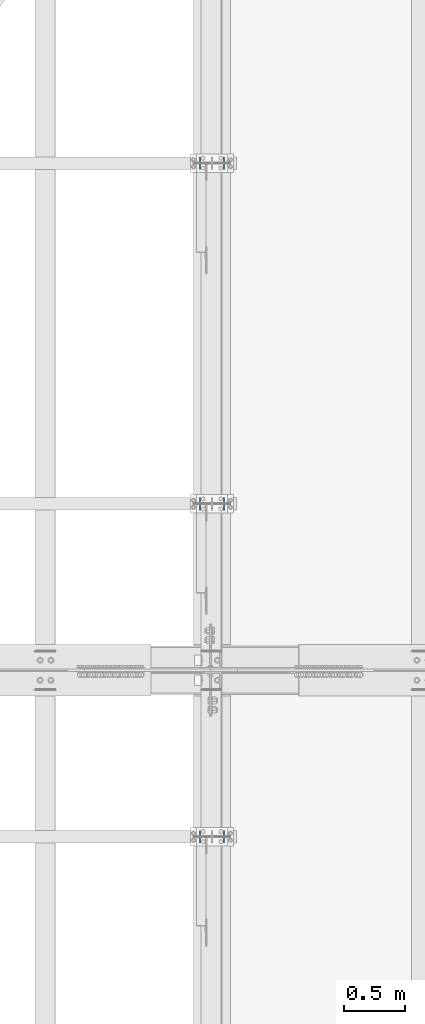
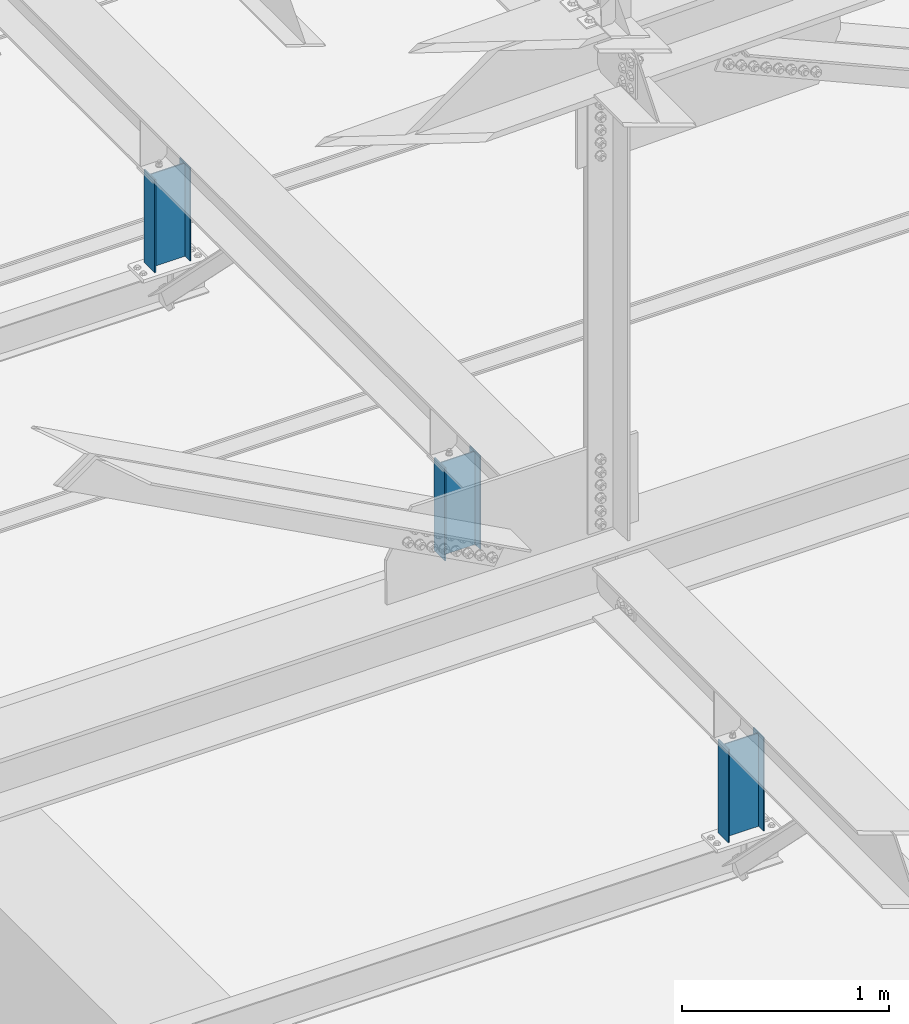
# One storey, part 1516 of 3843: 3 columns, 3 elements without a shape of their own.
"""IFC2X3 building model written with IfcOpenShell, lengths in millimetres."""

from ifc_helpers import new_model, si_unit, frame, origin_with_axes, place, context, subcontext, project, spatial, faceted_brep, material, type_object, element, aggregate, save


model = new_model("IFC2X3")

# Units and contexts
model_context = context("Model", 3, precision=1e-05, world=origin_with_axes())
body_context = subcontext(model_context, "Body", "Model", "MODEL_VIEW")
ifc_project = project(units=[si_unit("LENGTHUNIT", "METRE", prefix="MILLI"), si_unit("AREAUNIT", "SQUARE_METRE"), si_unit("VOLUMEUNIT", "CUBIC_METRE"), si_unit("MASSUNIT", "GRAM", prefix="KILO"), si_unit("TIMEUNIT", "SECOND"), si_unit("PLANEANGLEUNIT", "RADIAN"), si_unit("SOLIDANGLEUNIT", "STERADIAN"), si_unit("THERMODYNAMICTEMPERATUREUNIT", "DEGREE_CELSIUS"), si_unit("LUMINOUSINTENSITYUNIT", "LUMEN")], contexts=[model_context])

# Site, building, storey
site_placement = place(None, origin_with_axes())
site = spatial("IfcSite", under=ifc_project, at=site_placement, CompositionType="ELEMENT")
building_placement = place(site_placement, origin_with_axes())
building = spatial("IfcBuilding", under=site, at=building_placement, Name="Undefined", CompositionType="ELEMENT")
storey_placement = place(building_placement, origin_with_axes())
storey = spatial("IfcBuildingStorey", under=building, at=storey_placement, Name="Undefined", CompositionType="ELEMENT", Elevation=0.0)

# Assembly, column
assembly_1_placement = place(storey_placement, origin_with_axes())
assembly_1 = element("IfcElementAssembly", 1, at=assembly_1_placement, inside=storey, Name="POST", AssemblyPlace="NOTDEFINED", PredefinedType="RIGID_FRAME")
ifc_material = material(Name="STEEL/A992")
column_type = type_object("IfcColumnType", Name="W8X13", PredefinedType="NOTDEFINED")
column_1_placement = place(assembly_1_placement, frame((42062.4, 40830.5, 41503.6), z_axis=(-1.0, 0.0, 0.0), x_axis=(0.0, 0.0, 1.0)))
column_1 = element("IfcColumn", 2, at=column_1_placement, type_object=column_type, material=ifc_material, Name="POST", ObjectType="W8X13", context=body_context, shape_type="Brep", body=[
    faceted_brep([(19.0499994920028, 50.7999999999993, -101.600000000035), (19.0499995237551, 50.7999999999993, -95.2500000000364), (569.912499523743, 50.8000000000029, -95.2500000008076), (569.912499491991, 50.8000000000029, -101.600000000806), (19.0499995237551, 3.17499999999927, -95.2500000000364), (569.912499523743, 3.17500000000291, -95.2500000008076), (19.0500004762507, 3.17499999999927, 95.2499999999636), (569.912500476239, 3.17500000000291, 95.2499999991924), (19.0500004762507, 50.7999999999993, 95.2499999999636), (569.912500476239, 50.8000000000029, 95.2499999991924), (19.050000508003, 50.7999999999993, 101.599999999969), (569.912500507991, 50.8000000000029, 101.599999999191), (19.050000508003, -50.7999999999993, 101.599999999969), (569.912500507991, -50.8000000000029, 101.599999999191), (19.0500004762507, -50.7999999999993, 95.2499999999636), (569.912500476239, -50.8000000000029, 95.2499999991924), (19.0500004762507, -3.17499999999927, 95.2499999999636), (569.912500476239, -3.17500000000291, 95.2499999991924), (19.0499995237551, -3.17499999999927, -95.2500000000364), (569.912499523743, -3.17500000000291, -95.2500000008076), (19.0499995237551, -50.7999999999993, -95.2500000000364), (569.912499523743, -50.8000000000029, -95.2500000008076), (19.0499994920028, -50.7999999999993, -101.600000000035), (569.912499491991, -50.8000000000029, -101.600000000806)], [[[0, 1, 2, 3]], [[1, 4, 5, 2]], [[4, 6, 7, 5]], [[6, 8, 9, 7]], [[8, 10, 11, 9]], [[10, 12, 13, 11]], [[12, 14, 15, 13]], [[14, 16, 17, 15]], [[16, 18, 19, 17]], [[18, 20, 21, 19]], [[20, 22, 23, 21]], [[22, 0, 3, 23]], [[5, 7, 9, 11, 13, 15, 17, 19, 21, 23, 3, 2]], [[22, 20, 18, 16, 14, 12, 10, 8, 6, 4, 1, 0]]]),
])
aggregate(assembly_1, [column_1])

assembly_2_placement = place(storey_placement, origin_with_axes())
assembly_2 = element("IfcElementAssembly", 3, at=assembly_2_placement, inside=storey, Name="POST", AssemblyPlace="NOTDEFINED", PredefinedType="RIGID_FRAME")
column_2_placement = place(assembly_2_placement, frame((42062.4, 43573.7, 41503.6), z_axis=(-1.0, 0.0, 0.0), x_axis=(0.0, 0.0, 1.0)))
column_2 = element("IfcColumn", 4, at=column_2_placement, type_object=column_type, material=ifc_material, Name="POST", ObjectType="W8X13", context=body_context, shape_type="Brep", body=[
    faceted_brep([(19.0499994920028, 50.7999999999993, -101.600000000035), (19.0499995237551, 50.7999999999993, -95.2500000000364), (569.898883661845, 50.8000000000029, -95.2500000008076), (569.898883630092, 50.8000000000029, -101.600000000813), (19.0499995237551, 3.17499999999927, -95.2500000000364), (569.873359039419, 3.17500000000291, -95.2500000008076), (19.0500004762507, 3.17499999999927, 95.2499999999636), (569.873359991914, 3.17500000000291, 95.2499999991924), (19.0500004762507, 50.7999999999993, 95.2499999999636), (569.89888461434, 50.8000000000029, 95.2499999991924), (19.050000508003, 50.7999999999993, 101.599999999969), (569.898884646092, 50.8000000000029, 101.599999999191), (19.050000508003, -50.7999999999993, 101.599999999969), (569.844432118254, -50.8000000000029, 101.599999999191), (19.0500004762507, -50.7999999999993, 95.2499999999636), (569.844432086502, -50.8000000000029, 95.2499999991924), (19.0500004762507, -3.17499999999927, 95.2499999999636), (569.869956708928, -3.17500000000291, 95.2499999991924), (19.0499995237551, -3.17499999999927, -95.2500000000364), (569.869955756432, -3.17500000000291, -95.2500000008076), (19.0499995237551, -50.7999999999993, -95.2500000000364), (569.844431134006, -50.8000000000029, -95.2500000008076), (19.0499994920028, -50.7999999999993, -101.600000000035), (569.844431102254, -50.8000000000029, -101.600000000806)], [[[0, 1, 2, 3]], [[1, 4, 5, 2]], [[4, 6, 7, 5]], [[6, 8, 9, 7]], [[8, 10, 11, 9]], [[10, 12, 13, 11]], [[12, 14, 15, 13]], [[14, 16, 17, 15]], [[16, 18, 19, 17]], [[18, 20, 21, 19]], [[20, 22, 23, 21]], [[22, 0, 3, 23]], [[5, 7, 9, 11, 13, 15, 17, 19, 21, 23, 3, 2]], [[22, 20, 18, 16, 14, 12, 10, 8, 6, 4, 1, 0]]]),
])
aggregate(assembly_2, [column_2])

assembly_3_placement = place(storey_placement, origin_with_axes())
assembly_3 = element("IfcElementAssembly", 5, at=assembly_3_placement, inside=storey, Name="POST", AssemblyPlace="NOTDEFINED", PredefinedType="RIGID_FRAME")
column_3_placement = place(assembly_3_placement, frame((42062.4, 46380.4, 41503.6), z_axis=(-1.0, 0.0, 0.0), x_axis=(0.0, 0.0, 1.0)))
column_3 = element("IfcColumn", 6, at=column_3_placement, type_object=column_type, material=ifc_material, Name="POST", ObjectType="W8X13", context=body_context, shape_type="Brep", body=[
    faceted_brep([(19.0499994920028, 50.7999999999993, -101.600000000035), (19.0499995237551, 50.7999999999993, -95.2500000000364), (569.898883661845, 50.8000000000029, -95.2500000008076), (569.898883630092, 50.8000000000029, -101.600000000813), (19.0499995237551, 3.17499999999927, -95.2500000000364), (569.873359039419, 3.17500000000291, -95.2500000008076), (19.0500004762507, 3.17499999999927, 95.2499999999636), (569.873359991914, 3.17500000000291, 95.2499999991924), (19.0500004762507, 50.7999999999993, 95.2499999999636), (569.89888461434, 50.8000000000029, 95.2499999991924), (19.050000508003, 50.7999999999993, 101.599999999969), (569.898884646092, 50.8000000000029, 101.599999999191), (19.050000508003, -50.7999999999993, 101.599999999969), (569.844432118254, -50.8000000000029, 101.599999999191), (19.0500004762507, -50.7999999999993, 95.2499999999636), (569.844432086502, -50.8000000000029, 95.2499999991924), (19.0500004762507, -3.17499999999927, 95.2499999999636), (569.869956708928, -3.17500000000291, 95.2499999991924), (19.0499995237551, -3.17499999999927, -95.2500000000364), (569.869955756432, -3.17500000000291, -95.2500000008076), (19.0499995237551, -50.7999999999993, -95.2500000000364), (569.844431134006, -50.8000000000029, -95.2500000008076), (19.0499994920028, -50.7999999999993, -101.600000000035), (569.844431102254, -50.8000000000029, -101.600000000806)], [[[0, 1, 2, 3]], [[1, 4, 5, 2]], [[4, 6, 7, 5]], [[6, 8, 9, 7]], [[8, 10, 11, 9]], [[10, 12, 13, 11]], [[12, 14, 15, 13]], [[14, 16, 17, 15]], [[16, 18, 19, 17]], [[18, 20, 21, 19]], [[20, 22, 23, 21]], [[22, 0, 3, 23]], [[5, 7, 9, 11, 13, 15, 17, 19, 21, 23, 3, 2]], [[22, 20, 18, 16, 14, 12, 10, 8, 6, 4, 1, 0]]]),
])
aggregate(assembly_3, [column_3])

save(model, "model.ifc")
